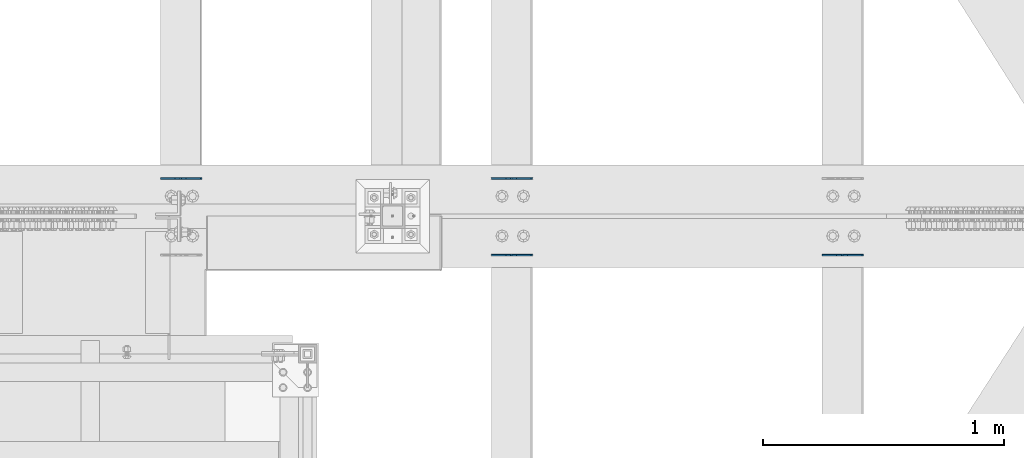
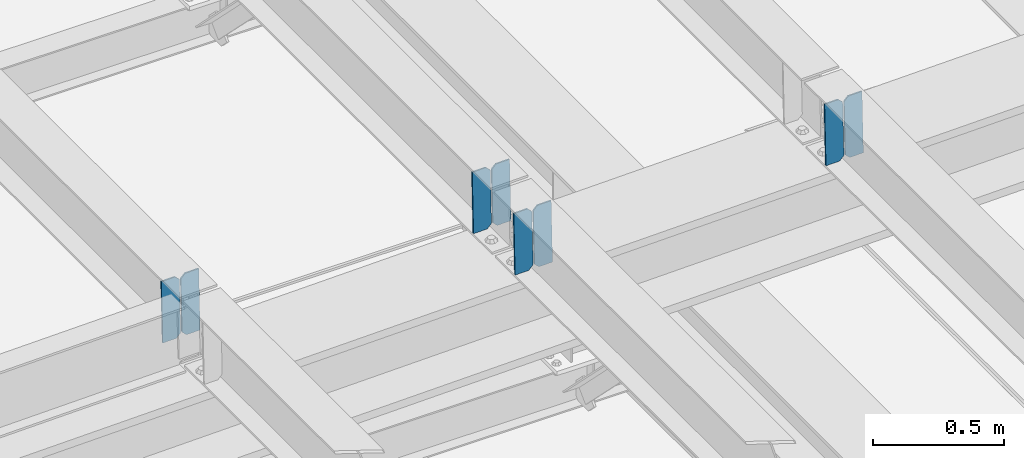
# One storey, part 3219 of 3843: 8 plates, 4 elements without a shape of their own.
"""IFC2X3 building model written with IfcOpenShell, lengths in millimetres."""

import ifcopenshell
import ifcopenshell.guid

model = None  # the IFC model being written
_history = None  # IfcOwnerHistory: only IFC2X3 demands one
_inside = {}  # id of a spatial element -> (the spatial element, [elements in it])
_under = {}  # id of a project, library or spatial element -> (it, [spatial elements below it])
_declared = {}  # id of a project -> (the project, [libraries it declares])
_typed = {}  # id of a type object -> (the type object, [elements of that type])
_made_of = {}  # id of a material, layer set ... -> (it, [elements and type objects made of it])


def new_model(schema):
    """Start an empty IFC model of exactly this schema.

    Asked for "IFC4X3", IfcOpenShell would pick the latest addendum, in which some entities
    have other attributes; the version numbers below select the first issue.
    IFC2X3 requires an IfcOwnerHistory on every rooted entity: one is made here for all.
    """
    global model, _history
    if schema == "IFC4X3":
        model = ifcopenshell.file(schema_version=(4, 3, 0, 0))
    else:
        model = ifcopenshell.file(schema=schema)
    _inside.clear()
    _under.clear()
    _declared.clear()
    _typed.clear()
    _made_of.clear()
    _history = None
    if model.schema == "IFC2X3":
        org = make("IfcOrganization", Name="unknown")
        user = make(
            "IfcPersonAndOrganization",
            ThePerson=make("IfcPerson", FamilyName="unknown"),
            TheOrganization=org,
        )
        app = make(
            "IfcApplication",
            ApplicationDeveloper=org,
            Version="unknown",
            ApplicationFullName="unknown",
            ApplicationIdentifier="unknown",
        )
        _history = make(
            "IfcOwnerHistory",
            OwningUser=user,
            OwningApplication=app,
            ChangeAction="ADDED",
            CreationDate=0,
        )
    return model


def make(cls, **values):
    """One entity of the class cls with the attributes given. An attribute that is None is left unset."""
    return model.create_entity(
        cls, **{name: value for name, value in values.items() if value is not None}
    )


def rooted(cls, **values):
    """An entity with a GlobalId (a new one), such as an element, a storey or a relation."""
    return make(cls, GlobalId=ifcopenshell.guid.new(), OwnerHistory=_history, **values)


def si_unit(unit_type, name, prefix=None):
    """IfcSIUnit, for example si_unit("LENGTHUNIT", "METRE", prefix="MILLI")."""
    return make("IfcSIUnit", UnitType=unit_type, Prefix=prefix, Name=name)


def assignment(units):
    """IfcUnitAssignment: the units of a project."""
    return None if units is None else make("IfcUnitAssignment", Units=units)


def point(xyz):
    """IfcCartesianPoint."""
    return None if xyz is None else make("IfcCartesianPoint", Coordinates=xyz)


def direction(xyz):
    """IfcDirection."""
    return None if xyz is None else make("IfcDirection", DirectionRatios=xyz)


def frame(location, z_axis=None, x_axis=None):
    """IfcAxis2Placement3D, a coordinate frame: its origin and axes. An axis left out is left unset."""
    return make(
        "IfcAxis2Placement3D",
        Location=point(location),
        Axis=direction(z_axis),
        RefDirection=direction(x_axis),
    )


def origin_with_axes():
    """The frame at (0, 0, 0) with the z axis (0, 0, 1) and the x axis (1, 0, 0) written out."""
    return frame((0.0, 0.0, 0.0), z_axis=(0.0, 0.0, 1.0), x_axis=(1.0, 0.0, 0.0))


def place(relative_to, where):
    """IfcLocalPlacement: puts the frame where relative to a parent placement (None: the world)."""
    return make(
        "IfcLocalPlacement", PlacementRelTo=relative_to, RelativePlacement=where
    )


def context(
    kind, dimensions, precision=None, world=None, true_north=None, identifier=None
):
    """IfcGeometricRepresentationContext, for example the 3D "Model" context."""
    return make(
        "IfcGeometricRepresentationContext",
        ContextIdentifier=identifier,
        ContextType=kind,
        CoordinateSpaceDimension=dimensions,
        Precision=precision,
        WorldCoordinateSystem=world,
        TrueNorth=true_north,
    )


def subcontext(parent, identifier, kind, view, scale=None):
    """IfcGeometricRepresentationSubContext, for example "Body" below "Model"."""
    return make(
        "IfcGeometricRepresentationSubContext",
        ContextIdentifier=identifier,
        ContextType=kind,
        ParentContext=parent,
        TargetScale=scale,
        TargetView=view,
    )


def project(units=None, contexts=None):
    """IfcProject with its units and contexts."""
    return rooted(
        "IfcProject",
        Name="project",
        RepresentationContexts=contexts,
        UnitsInContext=assignment(units),
    )


def spatial(cls, under=None, at=None, **own):
    """A site, building, storey or space (cls), placed at a placement, below another one or the project."""
    s = rooted(cls, ObjectPlacement=at, **own)
    if under is not None:
        _under.setdefault(under.id(), (under, []))[1].append(s)
    return s


def faces_of(points, faces, orient=None, outer=None):
    """IfcFace entities. A face is a list of loops; a loop is a list of indices into points, from 0.

    orient and outer hold one flag for each loop. By default every Orientation is true, the
    first loop of a face is its IfcFaceOuterBound and the others are IfcFaceBound.
    """
    made = []
    for i, loops in enumerate(faces):
        bounds = []
        for j, loop in enumerate(loops):
            is_outer = j == 0 if outer is None else outer[i][j]
            bounds.append(
                make(
                    "IfcFaceOuterBound" if is_outer else "IfcFaceBound",
                    Bound=make("IfcPolyLoop", Polygon=[points[k] for k in loop]),
                    Orientation=True if orient is None else orient[i][j],
                )
            )
        made.append(make("IfcFace", Bounds=bounds))
    return made


def faceted_brep(points, faces, orient=None, outer=None, voids=None):
    """IfcFacetedBrep: a solid bounded by flat faces; with voids (closed shells), ...WithVoids."""
    shared = [point(p) for p in points]
    hull = make("IfcClosedShell", CfsFaces=faces_of(shared, faces, orient, outer))
    if voids is None:
        return make("IfcFacetedBrep", Outer=hull)
    return make(
        "IfcFacetedBrepWithVoids",
        Outer=hull,
        Voids=[
            make(cls, CfsFaces=faces_of(shared, fs, o, b)) for cls, fs, o, b in voids
        ],
    )


def shape(context_of_items, identifier, shape_type, items):
    """IfcShapeRepresentation: the items that make up one representation, for example the "Body"."""
    return make(
        "IfcShapeRepresentation",
        ContextOfItems=context_of_items,
        RepresentationIdentifier=identifier,
        RepresentationType=shape_type,
        Items=items,
    )


def material(Name=None, Category=None):
    """IfcMaterial."""
    return make("IfcMaterial", Name=Name, Category=Category)


def made_of(thing, what):
    """Note that an element or type object is made of a material, layer set ...; save() writes the relation."""
    if what is not None:
        _made_of.setdefault(what.id(), (what, []))[1].append(thing)
    return thing


def type_object(cls, material=None, **own):
    """A type object (cls), such as IfcWallType, which elements share."""
    return made_of(rooted(cls, **own), material)


def element(
    cls,
    number,
    at=None,
    inside=None,
    cuts=None,
    type_object=None,
    material=None,
    context=None,
    identifier="Body",
    shape_type=None,
    held_by="IfcProductDefinitionShape",
    body=None,
    shapes=None,
    **own,
):
    """One element of the class cls, such as IfcWall. Its Tag is "e" and its number.

    at: its placement. inside: the storey or other place that contains it. cuts: it is an
    opening in that element (IfcRelVoidsElement). A single representation is given by context,
    identifier, shape_type and body (its items); several are given by shapes. held_by: the class
    of the entity that holds the representations. save() writes the other relations.
    """
    e = rooted(cls, Tag="e%d" % number, ObjectPlacement=at, **own)
    if body is not None:
        shapes = [shape(context, identifier, shape_type, body)]
    if shapes is not None:
        e.Representation = make(held_by, Representations=shapes)
    if inside is not None:
        _inside.setdefault(inside.id(), (inside, []))[1].append(e)
    if cuts is not None:
        rooted(
            "IfcRelVoidsElement", RelatingBuildingElement=cuts, RelatedOpeningElement=e
        )
    if type_object is not None:
        _typed.setdefault(type_object.id(), (type_object, []))[1].append(e)
    return made_of(e, material)


def aggregate(whole, parts):
    """IfcRelAggregates: a whole, such as a stair, and the parts it consists of."""
    return rooted("IfcRelAggregates", RelatingObject=whole, RelatedObjects=parts)


def save(model, path):
    """Write the relations noted so far, then the file.

    IfcRelAggregates (storeys below a building ...), IfcRelContainedInSpatialStructure (elements
    in a storey), IfcRelDefinesByType, IfcRelAssociatesMaterial and IfcRelDeclares: one each for
    every whole, place, type object, material and project.
    """
    for whole, parts in _under.values():
        aggregate(whole, parts)
    for where, things in _inside.values():
        rooted(
            "IfcRelContainedInSpatialStructure",
            RelatedElements=things,
            RelatingStructure=where,
        )
    for kind, things in _typed.values():
        rooted("IfcRelDefinesByType", RelatedObjects=things, RelatingType=kind)
    for what, things in _made_of.values():
        rooted("IfcRelAssociatesMaterial", RelatedObjects=things, RelatingMaterial=what)
    for by, libraries in _declared.values():
        rooted("IfcRelDeclares", RelatingContext=by, RelatedDefinitions=libraries)
    model.write(path)


model = new_model("IFC2X3")

# Units and contexts
model_context = context("Model", 3, precision=1e-05, world=origin_with_axes())
body_context = subcontext(model_context, "Body", "Model", "MODEL_VIEW")
ifc_project = project(units=[si_unit("LENGTHUNIT", "METRE", prefix="MILLI"), si_unit("AREAUNIT", "SQUARE_METRE"), si_unit("VOLUMEUNIT", "CUBIC_METRE"), si_unit("MASSUNIT", "GRAM", prefix="KILO"), si_unit("TIMEUNIT", "SECOND"), si_unit("PLANEANGLEUNIT", "RADIAN"), si_unit("SOLIDANGLEUNIT", "STERADIAN"), si_unit("THERMODYNAMICTEMPERATUREUNIT", "DEGREE_CELSIUS"), si_unit("LUMINOUSINTENSITYUNIT", "LUMEN")], contexts=[model_context])

# Site, building, storey
site_placement = place(None, origin_with_axes())
site = spatial("IfcSite", under=ifc_project, at=site_placement, CompositionType="ELEMENT")
building_placement = place(site_placement, origin_with_axes())
building = spatial("IfcBuilding", under=site, at=building_placement, Name="Undefined", CompositionType="ELEMENT")
storey_placement = place(building_placement, origin_with_axes())
storey = spatial("IfcBuildingStorey", under=building, at=storey_placement, Name="Undefined", CompositionType="ELEMENT", Elevation=0.0)

# Assembly, plates
assembly_1_placement = place(storey_placement, origin_with_axes())
assembly_1 = element("IfcElementAssembly", 1, at=assembly_1_placement, inside=storey, Name="BEAM", AssemblyPlace="NOTDEFINED", PredefinedType="RIGID_FRAME")
ifc_material = material(Name="STEEL/A572-50")
plate_type = type_object("IfcPlateType", PredefinedType="NOTDEFINED")
plate_1_placement = place(assembly_1_placement, frame((38029.8964782865, 34001.3013575639, 45461.0299104533), z_axis=(-0.0211520981049397, -0.000759152000093307, 0.999775981124772), x_axis=(-0.999776269340625, 1.63419999910023e-05, -0.0211520920071787)))
plate_1 = element("IfcPlate", 2, at=plate_1_placement, type_object=plate_type, material=ifc_material, Name="PLATE", context=body_context, shape_type="Brep", body=[
    faceted_brep([(0.0, -3.17499999999927, 0.0), (6.83940015733242e-10, -3.17499999996653, 288.924999998613), (6.54836185276508e-10, 3.17500000001746, 288.924999998591), (0.0, 3.17499999999927, 0.0), (60.3250007643655, -3.17500000017753, 288.924999998606), (60.3250007643219, 3.17499999979918, 288.924999998584), (79.3750000013097, -3.17500000025029, 269.875000761494), (79.375000001266, 3.17499999972642, 269.875000761487), (79.375000000713, -3.17500000026484, 19.0499992370605), (79.3750000006985, 3.17499999971187, 19.0499992370533), (60.325000763667, -3.17500000020664, -1.45519152283669e-11), (60.3250007636234, 3.17499999977736, -3.63797880709171e-11)], [[[0, 1, 2, 3]], [[1, 4, 5, 2]], [[4, 6, 7, 5]], [[6, 8, 9, 7]], [[8, 10, 11, 9]], [[10, 0, 3, 11]], [[5, 7, 9, 11, 3, 2]], [[10, 8, 6, 4, 1, 0]]]),
])
plate_2_placement = place(assembly_1_placement, frame((37944.1906575968, 34001.3027344131, 45459.2166473748), z_axis=(-0.0211520981049397, -0.000759152000093307, 0.999775981124772), x_axis=(-0.999776269340625, 1.63419999910023e-05, -0.0211520920071787)))
plate_2 = element("IfcPlate", 3, at=plate_2_placement, type_object=plate_type, material=ifc_material, Name="PLATE", context=body_context, shape_type="Brep", body=[
    faceted_brep([(4.36557456851006e-11, -3.17499999998836, 19.0499992370969), (6.11180439591408e-10, -3.17499999996653, 269.875000761516), (5.96628524363041e-10, 3.17500000001746, 269.875000761502), (1.45519152283669e-11, 3.17499999998836, 19.0499992370824), (19.0499992376572, -3.17500000003201, 288.924999998606), (19.0499992376281, 3.1749999999447, 288.924999998584), (79.3750000013242, -3.17500000025029, 288.924999998591), (79.3750000013097, 3.1749999997337, 288.92499999857), (79.3750000006548, -3.17500000026484, -2.18278728425503e-11), (79.3750000006403, 3.17499999969732, -2.91038304567337e-11), (19.0499992370023, -3.17500000005384, 0.0), (19.0499992369587, 3.17499999992287, -1.45519152283669e-11)], [[[0, 1, 2, 3]], [[1, 4, 5, 2]], [[4, 6, 7, 5]], [[6, 8, 9, 7]], [[8, 10, 11, 9]], [[10, 0, 3, 11]], [[5, 7, 9, 11, 3, 2]], [[10, 8, 6, 4, 1, 0]]]),
])
aggregate(assembly_1, [plate_1, plate_2])

assembly_2_placement = place(storey_placement, origin_with_axes())
assembly_2 = element("IfcElementAssembly", 4, at=assembly_2_placement, inside=storey, Name="BEAM", AssemblyPlace="NOTDEFINED", PredefinedType="RIGID_FRAME")
plate_3_placement = place(assembly_2_placement, frame((40773.0964782641, 33683.6398668271, 45520.2371341444), z_axis=(-0.0211520975410968, -0.000224554000033095, 0.999776244139214), x_axis=(-0.999776269357106, 4.75099998682526e-06, -0.0211520970075359)))
plate_3 = element("IfcPlate", 5, at=plate_3_placement, type_object=plate_type, material=ifc_material, Name="PLATE", context=body_context, shape_type="Brep", body=[
    faceted_brep([(0.0, -3.17499999999927, 0.0), (6.83940015733242e-10, -3.17499999996653, 288.924999998613), (6.54836185276508e-10, 3.17500000001746, 288.924999998591), (0.0, 3.17499999999927, 0.0), (60.3250007643655, -3.17500000017753, 288.924999998606), (60.3250007643219, 3.17499999979918, 288.924999998584), (79.3750000013097, -3.17500000025029, 269.875000761494), (79.375000001266, 3.17499999972642, 269.875000761487), (79.375000000713, -3.17500000026484, 19.0499992370605), (79.3750000006985, 3.17499999971187, 19.0499992370533), (60.325000763667, -3.17500000020664, -1.45519152283669e-11), (60.3250007636234, 3.17499999977736, -3.63797880709171e-11)], [[[0, 1, 2, 3]], [[1, 4, 5, 2]], [[4, 6, 7, 5]], [[6, 8, 9, 7]], [[8, 10, 11, 9]], [[10, 0, 3, 11]], [[5, 7, 9, 11, 3, 2]], [[10, 8, 6, 4, 1, 0]]]),
])
plate_4_placement = place(assembly_2_placement, frame((40687.3906575748, 33683.6402638265, 45518.4238705867), z_axis=(-0.0211520975410968, -0.000224554000033095, 0.999776244139214), x_axis=(-0.999776269357106, 4.75099998682526e-06, -0.0211520970075359)))
plate_4 = element("IfcPlate", 6, at=plate_4_placement, type_object=plate_type, material=ifc_material, Name="PLATE", context=body_context, shape_type="Brep", body=[
    faceted_brep([(4.36557456851006e-11, -3.17499999998836, 19.0499992370969), (6.11180439591408e-10, -3.17499999996653, 269.875000761516), (5.96628524363041e-10, 3.17500000001746, 269.875000761502), (1.45519152283669e-11, 3.17499999998836, 19.0499992370824), (19.0499992376572, -3.17500000003201, 288.924999998606), (19.0499992376281, 3.1749999999447, 288.924999998584), (79.3750000013242, -3.17500000025029, 288.924999998591), (79.3750000013097, 3.1749999997337, 288.92499999857), (79.3750000006548, -3.17500000026484, -2.18278728425503e-11), (79.3750000006403, 3.17499999969732, -2.91038304567337e-11), (19.0499992370023, -3.17500000005384, 0.0), (19.0499992369587, 3.17499999992287, -1.45519152283669e-11)], [[[0, 1, 2, 3]], [[1, 4, 5, 2]], [[4, 6, 7, 5]], [[6, 8, 9, 7]], [[8, 10, 11, 9]], [[10, 0, 3, 11]], [[5, 7, 9, 11, 3, 2]], [[10, 8, 6, 4, 1, 0]]]),
])
aggregate(assembly_2, [plate_3, plate_4])

assembly_3_placement = place(storey_placement, origin_with_axes())
assembly_3 = element("IfcElementAssembly", 7, at=assembly_3_placement, inside=storey, Name="BEAM", AssemblyPlace="NOTDEFINED", PredefinedType="RIGID_FRAME")
plate_5_placement = place(assembly_3_placement, frame((39401.4964782748, 34001.5161575889, 45490.8230740156), z_axis=(-0.0211520981862632, -0.00148010699961742, 0.99977517373937), x_axis=(-0.999776269354784, 3.22880000190736e-05, -0.0211520730075225)))
plate_5 = element("IfcPlate", 8, at=plate_5_placement, type_object=plate_type, material=ifc_material, Name="PLATE", context=body_context, shape_type="Brep", body=[
    faceted_brep([(0.0, -3.17499999999927, 0.0), (6.83940015733242e-10, -3.17499999996653, 288.924999998613), (6.54836185276508e-10, 3.17500000001746, 288.924999998591), (0.0, 3.17499999999927, 0.0), (60.3250007643655, -3.17500000017753, 288.924999998606), (60.3250007643219, 3.17499999979918, 288.924999998584), (79.3750000013097, -3.17500000025029, 269.875000761494), (79.375000001266, 3.17499999972642, 269.875000761487), (79.375000000713, -3.17500000026484, 19.0499992370605), (79.3750000006985, 3.17499999971187, 19.0499992370533), (60.325000763667, -3.17500000020664, -1.45519152283669e-11), (60.3250007636234, 3.17499999977736, -3.63797880709171e-11)], [[[0, 1, 2, 3]], [[1, 4, 5, 2]], [[4, 6, 7, 5]], [[6, 8, 9, 7]], [[8, 10, 11, 9]], [[10, 0, 3, 11]], [[5, 7, 9, 11, 3, 2]], [[10, 8, 6, 4, 1, 0]]]),
])
plate_6_placement = place(assembly_3_placement, frame((39315.7906575855, 34001.5188420132, 45489.0098124025), z_axis=(-0.0211520981862632, -0.00148010699961742, 0.99977517373937), x_axis=(-0.999776269354784, 3.22880000190736e-05, -0.0211520730075225)))
plate_6 = element("IfcPlate", 9, at=plate_6_placement, type_object=plate_type, material=ifc_material, Name="PLATE", context=body_context, shape_type="Brep", body=[
    faceted_brep([(4.36557456851006e-11, -3.17499999998836, 19.0499992370969), (6.11180439591408e-10, -3.17499999996653, 269.875000761516), (5.96628524363041e-10, 3.17500000001746, 269.875000761502), (1.45519152283669e-11, 3.17499999998836, 19.0499992370824), (19.0499992376572, -3.17500000003201, 288.924999998606), (19.0499992376281, 3.1749999999447, 288.924999998584), (79.3750000013242, -3.17500000025029, 288.924999998591), (79.3750000013097, 3.1749999997337, 288.92499999857), (79.3750000006548, -3.17500000026484, -2.18278728425503e-11), (79.3750000006403, 3.17499999969732, -2.91038304567337e-11), (19.0499992370023, -3.17500000005384, 0.0), (19.0499992369587, 3.17499999992287, -1.45519152283669e-11)], [[[0, 1, 2, 3]], [[1, 4, 5, 2]], [[4, 6, 7, 5]], [[6, 8, 9, 7]], [[8, 10, 11, 9]], [[10, 0, 3, 11]], [[5, 7, 9, 11, 3, 2]], [[10, 8, 6, 4, 1, 0]]]),
])
aggregate(assembly_3, [plate_5, plate_6])

assembly_4_placement = place(storey_placement, origin_with_axes())
assembly_4 = element("IfcElementAssembly", 10, at=assembly_4_placement, inside=storey, Name="BEAM", AssemblyPlace="NOTDEFINED", PredefinedType="RIGID_FRAME")
plate_7_placement = place(assembly_4_placement, frame((39401.4964782613, 33683.6183395382, 45490.5684563997), z_axis=(-0.0211520982443181, -0.000149703000020964, 0.999776258134226), x_axis=(-0.999776269342228, 3.1669999978437e-06, -0.0211520980072307)))
plate_7 = element("IfcPlate", 11, at=plate_7_placement, type_object=plate_type, material=ifc_material, Name="PLATE", context=body_context, shape_type="Brep", body=[
    faceted_brep([(0.0, -3.17499999999927, 0.0), (6.83940015733242e-10, -3.17499999996653, 288.924999998613), (6.54836185276508e-10, 3.17500000001746, 288.924999998591), (0.0, 3.17499999999927, 0.0), (60.3250007643655, -3.17500000017753, 288.924999998606), (60.3250007643219, 3.17499999979918, 288.924999998584), (79.3750000013097, -3.17500000025029, 269.875000761494), (79.375000001266, 3.17499999972642, 269.875000761487), (79.375000000713, -3.17500000026484, 19.0499992370605), (79.3750000006985, 3.17499999971187, 19.0499992370533), (60.325000763667, -3.17500000020664, -1.45519152283669e-11), (60.3250007636234, 3.17499999977736, -3.63797880709171e-11)], [[[0, 1, 2, 3]], [[1, 4, 5, 2]], [[4, 6, 7, 5]], [[6, 8, 9, 7]], [[8, 10, 11, 9]], [[10, 0, 3, 11]], [[5, 7, 9, 11, 3, 2]], [[10, 8, 6, 4, 1, 0]]]),
])
plate_8_placement = place(assembly_4_placement, frame((39315.790657572, 33683.6186042035, 45488.7551928185), z_axis=(-0.0211520982443181, -0.000149703000020964, 0.999776258134226), x_axis=(-0.999776269342228, 3.1669999978437e-06, -0.0211520980072307)))
plate_8 = element("IfcPlate", 12, at=plate_8_placement, type_object=plate_type, material=ifc_material, Name="PLATE", context=body_context, shape_type="Brep", body=[
    faceted_brep([(4.36557456851006e-11, -3.17499999998836, 19.0499992370969), (6.11180439591408e-10, -3.17499999996653, 269.875000761516), (5.96628524363041e-10, 3.17500000001746, 269.875000761502), (1.45519152283669e-11, 3.17499999998836, 19.0499992370824), (19.0499992376572, -3.17500000003201, 288.924999998606), (19.0499992376281, 3.1749999999447, 288.924999998584), (79.3750000013242, -3.17500000025029, 288.924999998591), (79.3750000013097, 3.1749999997337, 288.92499999857), (79.3750000006548, -3.17500000026484, -2.18278728425503e-11), (79.3750000006403, 3.17499999969732, -2.91038304567337e-11), (19.0499992370023, -3.17500000005384, 0.0), (19.0499992369587, 3.17499999992287, -1.45519152283669e-11)], [[[0, 1, 2, 3]], [[1, 4, 5, 2]], [[4, 6, 7, 5]], [[6, 8, 9, 7]], [[8, 10, 11, 9]], [[10, 0, 3, 11]], [[5, 7, 9, 11, 3, 2]], [[10, 8, 6, 4, 1, 0]]]),
])
aggregate(assembly_4, [plate_7, plate_8])

save(model, "model.ifc")
